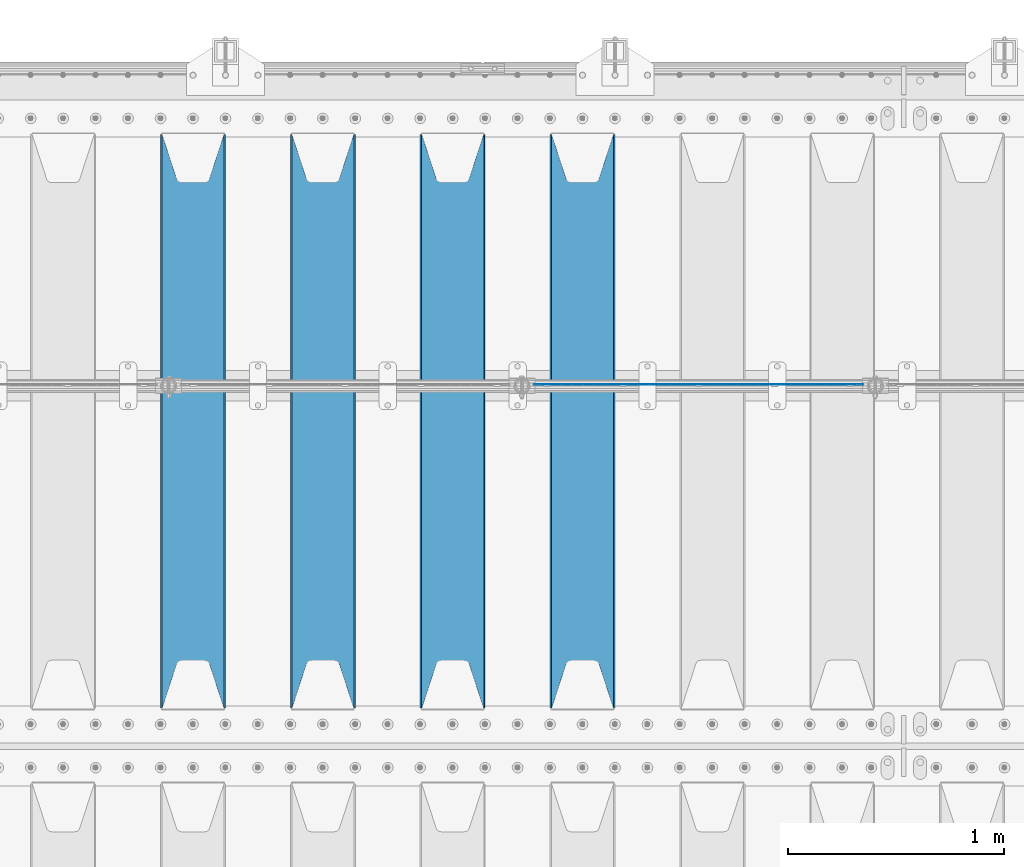
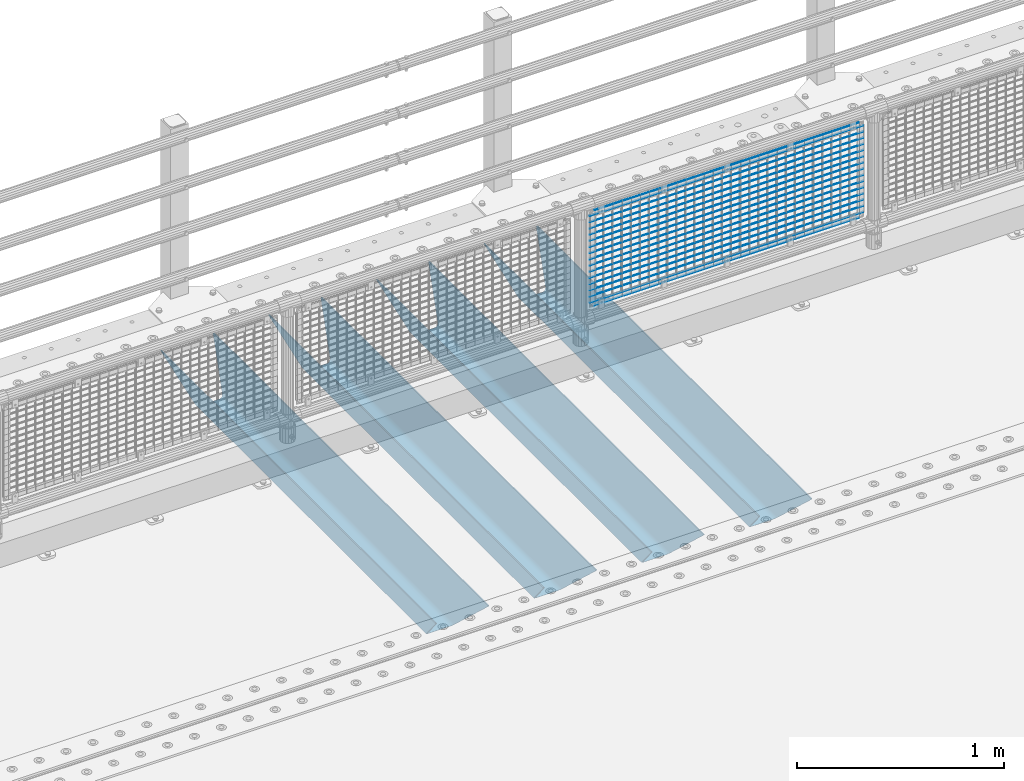
# One storey, part 116 of 242: 21 beams.
"""IFC2X3 building model written with IfcOpenShell, lengths in millimetres."""

from ifc_helpers import new_model, si_unit, frame, origin_with_axes, place, context, subcontext, project, spatial, faceted_brep, material, type_object, element, save


model = new_model("IFC2X3")

# Units and contexts
model_context = context("Model", 3, precision=1e-05, world=origin_with_axes())
body_context = subcontext(model_context, "Body", "Model", "MODEL_VIEW")
ifc_project = project(units=[si_unit("LENGTHUNIT", "METRE", prefix="MILLI"), si_unit("AREAUNIT", "SQUARE_METRE"), si_unit("VOLUMEUNIT", "CUBIC_METRE"), si_unit("MASSUNIT", "GRAM", prefix="KILO"), si_unit("TIMEUNIT", "SECOND"), si_unit("PLANEANGLEUNIT", "RADIAN"), si_unit("SOLIDANGLEUNIT", "STERADIAN"), si_unit("THERMODYNAMICTEMPERATUREUNIT", "DEGREE_CELSIUS"), si_unit("LUMINOUSINTENSITYUNIT", "LUMEN")], contexts=[model_context])

# Site, building, storey
site_placement = place(None, origin_with_axes())
site = spatial("IfcSite", under=ifc_project, at=site_placement, CompositionType="ELEMENT")
building_placement = place(site_placement, origin_with_axes())
building = spatial("IfcBuilding", under=site, at=building_placement, Name="Standard", CompositionType="ELEMENT")
storey_placement = place(building_placement, origin_with_axes())
storey = spatial("IfcBuildingStorey", under=building, at=storey_placement, Name="Undefined", CompositionType="ELEMENT", Elevation=0.0)

# Beams
ifc_material_1 = material(Name="Misc_Undefined")
beam_type_1 = type_object("IfcBeamType", Name="D3", PredefinedType="NOTDEFINED")
for number, where, z_axis, x_axis in (
    (1, (-36875.0, -19329.5, 851.596999999999), (0.0, 0.0, 1.0), (1.0, 0.0, 0.0)),
    (2, (-36875.0, -19329.5, 669.452), (0.0, 0.0, 1.0), (1.0, 0.0, 0.0)),
    (3, (-36875.0, -19329.5, 523.736), (0.0, 0.0, 1.0), (1.0, 0.0, 0.0)),
    (4, (-36875.0, -19329.5, 487.307), (0.0, 0.0, 1.0), (1.0, 0.0, 0.0)),
    (5, (-36875.0, -19329.5, 705.881), (0.0, 0.0, 1.0), (1.0, 0.0, 0.0)),
    (6, (-36875.0, -19329.5, 596.594), (0.0, 0.0, 1.0), (1.0, 0.0, 0.0)),
    (7, (-36875.0, -19329.5, 450.878), (0.0, 0.0, 1.0), (1.0, 0.0, 0.0)),
    (8, (-36875.0, -19329.5, 815.167999999999), (0.0, 0.0, 1.0), (1.0, 0.0, 0.0)),
    (9, (-36875.0, -19329.5, 888.025999999999), (0.0, 0.0, 1.0), (1.0, 0.0, 0.0)),
    (10, (-36875.0, -19329.5, 778.738999999999), (0.0, 0.0, 1.0), (1.0, 0.0, 0.0)),
    (11, (-36875.0, -19329.5, 742.309999999999), (0.0, 0.0, 1.0), (1.0, 0.0, 0.0)),
    (12, (-36875.0, -19329.5, 633.023), (0.0, 0.0, 1.0), (1.0, 0.0, 0.0)),
    (13, (-36875.0, -19329.5, 560.165), (0.0, 0.0, 1.0), (1.0, 0.0, 0.0)),
    (14, (-36875.0, -19329.5, 414.449), (0.0, 0.0, 1.0), (1.0, 0.0, 0.0)),
):
    element("IfcBeam", number, at=place(storey_placement, frame(where, z_axis=z_axis, x_axis=x_axis)), inside=storey, type_object=beam_type_1, material=ifc_material_1, ObjectType="D3", context=body_context, shape_type="Brep", body=[
        faceted_brep([(0.0, -1.50000000000364, 0.0), (-3.63797880709171e-12, -0.750000000003638, -1.29903810567669), (1523.0, -0.75, -1.29903810567669), (1523.0, -1.5, 0.0), (0.0, 0.749999999996362, -1.29903810567669), (1523.0, 0.75, -1.29903810567669), (-3.63797880709171e-12, 1.49999999999636, 0.0), (1523.0, 1.5, 0.0), (0.0, 0.749999999996362, 1.29903810567669), (1523.0, 0.75, 1.29903810567669), (-3.63797880709171e-12, -0.750000000003638, 1.29903810567669), (1523.0, -0.75, 1.29903810567669)], [[[0, 1, 2, 3]], [[1, 4, 5, 2]], [[4, 6, 7, 5]], [[6, 8, 9, 7]], [[8, 10, 11, 9]], [[10, 0, 3, 11]], [[5, 7, 9, 11, 3, 2]], [[10, 8, 6, 4, 1, 0]]]),
    ])
beam_1_placement = place(storey_placement, frame((-36850.0, -19329.5, 353.02), z_axis=(0.0, 0.0, 1.0), x_axis=(1.0, 0.0, 0.0)))
element("IfcBeam", 15, at=beam_1_placement, inside=storey, type_object=beam_type_1, material=ifc_material_1, ObjectType="D3", context=body_context, shape_type="Brep", body=[
    faceted_brep([(0.0, -1.50000000000364, 0.0), (-3.63797880709171e-12, -0.750000000003638, -1.29903810567669), (1473.0, -0.75, -1.29903810567669), (1473.0, -1.5, 0.0), (0.0, 0.749999999996362, -1.29903810567669), (1473.0, 0.75, -1.29903810567663), (-3.63797880709171e-12, 1.49999999999636, 0.0), (1473.0, 1.5, 0.0), (0.0, 0.749999999996362, 1.29903810567669), (1473.0, 0.75, 1.29903810567669), (-3.63797880709171e-12, -0.750000000003638, 1.29903810567669), (1473.0, -0.75, 1.29903810567669)], [[[0, 1, 2, 3]], [[1, 4, 5, 2]], [[4, 6, 7, 5]], [[6, 8, 9, 7]], [[8, 10, 11, 9]], [[10, 0, 3, 11]], [[5, 7, 9, 11, 3, 2]], [[10, 8, 6, 4, 1, 0]]]),
])
beam_2_placement = place(storey_placement, frame((-36875.0, -19329.5, 378.02), z_axis=(0.0, 0.0, 1.0), x_axis=(1.0, 0.0, 0.0)))
element("IfcBeam", 16, at=beam_2_placement, inside=storey, type_object=beam_type_1, material=ifc_material_1, ObjectType="D3", context=body_context, shape_type="Brep", body=[
    faceted_brep([(0.0, -1.50000000000364, 0.0), (-3.63797880709171e-12, -0.750000000003638, -1.29903810567669), (1523.0, -0.75, -1.29903810567669), (1523.0, -1.5, 0.0), (0.0, 0.749999999996362, -1.29903810567669), (1523.0, 0.75, -1.29903810567669), (-3.63797880709171e-12, 1.49999999999636, 0.0), (1523.0, 1.5, 0.0), (0.0, 0.749999999996362, 1.29903810567669), (1523.0, 0.75, 1.29903810567669), (-3.63797880709171e-12, -0.750000000003638, 1.29903810567669), (1523.0, -0.75, 1.29903810567669)], [[[0, 1, 2, 3]], [[1, 4, 5, 2]], [[4, 6, 7, 5]], [[6, 8, 9, 7]], [[8, 10, 11, 9]], [[10, 0, 3, 11]], [[5, 7, 9, 11, 3, 2]], [[10, 8, 6, 4, 1, 0]]]),
])
beam_3_placement = place(storey_placement, frame((-36850.0, -19329.5, 913.02), z_axis=(0.0, 0.0, 1.0), x_axis=(1.0, 0.0, 0.0)))
element("IfcBeam", 17, at=beam_3_placement, inside=storey, type_object=beam_type_1, material=ifc_material_1, ObjectType="D3", context=body_context, shape_type="Brep", body=[
    faceted_brep([(0.0, -1.50000000000364, 0.0), (-3.63797880709171e-12, -0.750000000003638, -1.29903810567669), (1473.0, -0.75, -1.29903810567669), (1473.0, -1.5, 0.0), (0.0, 0.749999999996362, -1.29903810567669), (1473.0, 0.75, -1.29903810567663), (-3.63797880709171e-12, 1.49999999999636, 0.0), (1473.0, 1.5, 0.0), (0.0, 0.749999999996362, 1.29903810567669), (1473.0, 0.75, 1.29903810567669), (-3.63797880709171e-12, -0.750000000003638, 1.29903810567669), (1473.0, -0.75, 1.29903810567669)], [[[0, 1, 2, 3]], [[1, 4, 5, 2]], [[4, 6, 7, 5]], [[6, 8, 9, 7]], [[8, 10, 11, 9]], [[10, 0, 3, 11]], [[5, 7, 9, 11, 3, 2]], [[10, 8, 6, 4, 1, 0]]]),
])
ifc_material_2 = material(Name="STEEL/S355N")
beam_type_2 = type_object("IfcBeamType", PredefinedType="NOTDEFINED")
beam_4_placement = place(storey_placement, frame((-36650.0, -20825.0, -115.0), z_axis=(0.0, 0.0, 1.0), x_axis=(0.0, 1.0, 0.0)))
element("IfcBeam", 18, at=beam_4_placement, inside=storey, type_object=beam_type_2, material=ifc_material_2, context=body_context, shape_type="Brep", body=[
    faceted_brep([(0.0, 150.0, 115.0), (0.0, 143.689999999999, 115.0), (2650.00000000297, 143.689999999999, 115.0), (2650.00000000297, 150.0, 115.0), (2650.00000000297, 142.059565218402, 110.000000003099), (2650.00000000297, 148.369565218403, 110.000000003099), (2441.90079219209, -80.1103600731112, -98.0992078077845), (2437.7588105432, -77.5672621345584, -102.241189456673), (2434.06523489747, -74.4080125315522, -105.934765102404), (2430.91086095089, -70.710272125576, -109.089139048974), (2428.37322971128, -66.5649389910068, -111.626770288588), (2426.51472138055, -62.0739139532889, -113.485278619323), (2425.38102192092, -57.3475956567672, -114.618978078955), (2424.99999999987, -52.5021667386536, -115.0), (2424.99999999987, 52.5021667386536, -115.0), (2425.38102192092, 57.3475956567672, -114.618978078955), (2426.51472138055, 62.0739139532889, -113.485278619323), (2428.37322971128, 66.5649389910068, -111.626770288588), (2430.91086095089, 70.710272125576, -109.089139048974), (2434.06523489747, 74.4080125315522, -105.934765102404), (2437.7588105432, 77.5672621345584, -102.241189456673), (2441.90079219209, 80.1103600731112, -98.0992078077846), (2446.38936140511, 81.9747917625791, -93.6106385947584), (2448.2494850041, 76.2713538057251, -91.7505149957729), (2444.62967112262, 74.76777986261, -95.3703288772456), (2441.28936334126, 72.7168944282894, -98.710636658607), (2438.31067330438, 70.1691124903846, -101.689326695487), (2435.76682334747, 67.1870637758839, -104.233176652398), (2433.72034654133, 63.8440531834895, -106.279653458539), (2432.22154950042, 60.222258798236, -107.778450499454), (2431.30727574265, 56.4107117849089, -108.692724257221), (2430.99999999987, 52.5031078186876, -109.0), (2430.99999999987, -52.5031078186876, -109.0), (2431.30727574265, -56.4107117849089, -108.692724257221), (2432.22154950042, -60.222258798236, -107.778450499454), (2433.72034654133, -63.8440531834895, -106.279653458539), (2435.76682334747, -67.1870637758839, -104.233176652398), (2438.31067330438, -70.1691124903846, -101.689326695487), (2441.28936334126, -72.7168944282894, -98.7106366586071), (2444.62967112262, -74.76777986261, -95.3703288772457), (2448.2494850041, -76.2713538057251, -91.7505149957729), (2650.00000000297, -142.059565218402, 110.000000003099), (2650.00000000297, -148.369565218403, 110.000000003099), (2446.38936140511, -81.9747917625791, -93.6106385947584), (2650.00000000297, -143.689999999999, 115.0), (2650.00000000297, -150.0, 115.0), (0.0, -143.689999999999, 115.0), (0.0, -150.0, 115.0), (0.0, -148.369565218261, 110.000000002669), (203.610638597427, -81.9747917625791, -93.6106385947584), (208.099207810454, -80.1103600731112, -98.0992078077845), (212.241189459342, -77.5672621345584, -102.241189456673), (215.934765105074, -74.4080125315522, -105.934765102404), (219.089139051644, -70.710272125576, -109.089139048974), (221.626770291256, -66.5649389910068, -111.626770288588), (223.485278621993, -62.0739139532889, -113.485278619323), (224.618978081624, -57.3475956567672, -114.618978078955), (225.00000000267, -52.5021667386536, -115.0), (225.00000000267, 52.5021667386536, -115.0), (224.618978081624, 57.3475956567672, -114.618978078955), (223.485278621993, 62.0739139532889, -113.485278619323), (221.626770291256, 66.5649389910068, -111.626770288588), (219.089139051644, 70.710272125576, -109.089139048974), (215.934765105074, 74.4080125315522, -105.934765102404), (212.241189459342, 77.5672621345584, -102.241189456673), (208.099207810454, 80.1103600731112, -98.0992078077846), (203.610638597427, 81.9747917625791, -93.6106385947584), (0.0, 148.369565218261, 110.000000002669), (0.0, 142.05956521826, 110.000000002669), (201.750514998443, 76.2713538057251, -91.7505149957729), (205.370328879915, 74.76777986261, -95.3703288772456), (208.710636661275, 72.7168944282894, -98.710636658607), (211.689326698157, 70.1691124903846, -101.689326695487), (214.233176655067, 67.1870637758839, -104.233176652398), (216.279653461206, 63.8440531834895, -106.279653458539), (217.778450502123, 60.222258798236, -107.778450499454), (218.69272425989, 56.4107117849089, -108.692724257221), (219.00000000267, 52.5031078186876, -109.0), (219.00000000267, -52.5031078186876, -109.0), (218.69272425989, -56.4107117849089, -108.692724257221), (217.778450502123, -60.222258798236, -107.778450499454), (216.279653461206, -63.8440531834895, -106.279653458539), (214.233176655067, -67.1870637758839, -104.233176652398), (211.689326698157, -70.1691124903846, -101.689326695487), (208.710636661275, -72.7168944282894, -98.7106366586071), (205.370328879915, -74.76777986261, -95.3703288772457), (201.750514998443, -76.2713538057251, -91.7505149957729), (0.0, -142.05956521826, 110.000000002669)], [[[0, 1, 2, 3]], [[3, 2, 4, 5]], [[6, 7, 8, 9, 10, 11, 12, 13, 14, 15, 16, 17, 18, 19, 20, 21, 22, 5, 4, 23, 24, 25, 26, 27, 28, 29, 30, 31, 32, 33, 34, 35, 36, 37, 38, 39, 40, 41, 42, 43]], [[44, 45, 42, 41]], [[46, 47, 45, 44]], [[43, 42, 45, 47, 48, 49]], [[6, 43, 49, 50]], [[7, 6, 50, 51]], [[8, 7, 51, 52]], [[9, 8, 52, 53]], [[10, 9, 53, 54]], [[11, 10, 54, 55]], [[12, 11, 55, 56]], [[13, 12, 56, 57]], [[14, 13, 57, 58]], [[15, 14, 58, 59]], [[16, 15, 59, 60]], [[17, 16, 60, 61]], [[18, 17, 61, 62]], [[19, 18, 62, 63]], [[20, 19, 63, 64]], [[21, 20, 64, 65]], [[22, 21, 65, 66]], [[0, 3, 5, 22, 66, 67]], [[1, 0, 67, 68]], [[23, 4, 2, 1, 68, 69]], [[24, 23, 69, 70]], [[25, 24, 70, 71]], [[26, 25, 71, 72]], [[27, 26, 72, 73]], [[28, 27, 73, 74]], [[29, 28, 74, 75]], [[30, 29, 75, 76]], [[31, 30, 76, 77]], [[32, 31, 77, 78]], [[33, 32, 78, 79]], [[34, 33, 79, 80]], [[35, 34, 80, 81]], [[36, 35, 81, 82]], [[37, 36, 82, 83]], [[38, 37, 83, 84]], [[39, 38, 84, 85]], [[40, 39, 85, 86]], [[46, 44, 41, 40, 86, 87]], [[47, 46, 87, 48]], [[86, 85, 84, 83, 82, 81, 80, 79, 78, 77, 76, 75, 74, 73, 72, 71, 70, 69, 68, 67, 66, 65, 64, 63, 62, 61, 60, 59, 58, 57, 56, 55, 54, 53, 52, 51, 50, 49, 48, 87]]]),
])
beam_5_placement = place(storey_placement, frame((-37250.0, -20825.0, -115.0), z_axis=(0.0, 0.0, 1.0), x_axis=(0.0, 1.0, 0.0)))
element("IfcBeam", 19, at=beam_5_placement, inside=storey, type_object=beam_type_2, material=ifc_material_2, context=body_context, shape_type="Brep", body=[
    faceted_brep([(0.0, 150.0, 115.0), (0.0, 143.689999999999, 115.0), (2650.00000000297, 143.689999999999, 115.0), (2650.00000000297, 150.0, 115.0), (2650.00000000297, 142.059565218402, 110.000000003099), (2650.00000000297, 148.369565218403, 110.000000003099), (2441.90079219209, -80.1103600731112, -98.0992078077845), (2437.7588105432, -77.5672621345584, -102.241189456673), (2434.06523489747, -74.4080125315522, -105.934765102404), (2430.91086095089, -70.710272125576, -109.089139048974), (2428.37322971128, -66.5649389910068, -111.626770288588), (2426.51472138055, -62.0739139532889, -113.485278619323), (2425.38102192092, -57.3475956567672, -114.618978078955), (2424.99999999987, -52.5021667386536, -115.0), (2424.99999999987, 52.5021667386536, -115.0), (2425.38102192092, 57.3475956567672, -114.618978078955), (2426.51472138055, 62.0739139532889, -113.485278619323), (2428.37322971128, 66.5649389910068, -111.626770288588), (2430.91086095089, 70.710272125576, -109.089139048974), (2434.06523489747, 74.4080125315522, -105.934765102404), (2437.7588105432, 77.5672621345584, -102.241189456673), (2441.90079219209, 80.1103600731112, -98.0992078077846), (2446.38936140511, 81.9747917625791, -93.6106385947584), (2448.2494850041, 76.2713538057251, -91.7505149957729), (2444.62967112262, 74.76777986261, -95.3703288772456), (2441.28936334126, 72.7168944282894, -98.710636658607), (2438.31067330438, 70.1691124903846, -101.689326695487), (2435.76682334747, 67.1870637758839, -104.233176652398), (2433.72034654133, 63.8440531834895, -106.279653458539), (2432.22154950042, 60.222258798236, -107.778450499454), (2431.30727574265, 56.4107117849089, -108.692724257221), (2430.99999999987, 52.5031078186876, -109.0), (2430.99999999987, -52.5031078186876, -109.0), (2431.30727574265, -56.4107117849089, -108.692724257221), (2432.22154950042, -60.222258798236, -107.778450499454), (2433.72034654133, -63.8440531834895, -106.279653458539), (2435.76682334747, -67.1870637758839, -104.233176652398), (2438.31067330438, -70.1691124903846, -101.689326695487), (2441.28936334126, -72.7168944282894, -98.7106366586071), (2444.62967112262, -74.76777986261, -95.3703288772457), (2448.2494850041, -76.2713538057251, -91.7505149957729), (2650.00000000297, -142.059565218402, 110.000000003099), (2650.00000000297, -148.369565218403, 110.000000003099), (2446.38936140511, -81.9747917625791, -93.6106385947584), (2650.00000000297, -143.689999999999, 115.0), (2650.00000000297, -150.0, 115.0), (0.0, -143.689999999999, 115.0), (0.0, -150.0, 115.0), (0.0, -148.369565218261, 110.000000002669), (203.610638597427, -81.9747917625791, -93.6106385947584), (208.099207810454, -80.1103600731112, -98.0992078077845), (212.241189459342, -77.5672621345584, -102.241189456673), (215.934765105074, -74.4080125315522, -105.934765102404), (219.089139051644, -70.710272125576, -109.089139048974), (221.626770291256, -66.5649389910068, -111.626770288588), (223.485278621993, -62.0739139532889, -113.485278619323), (224.618978081624, -57.3475956567672, -114.618978078955), (225.00000000267, -52.5021667386536, -115.0), (225.00000000267, 52.5021667386536, -115.0), (224.618978081624, 57.3475956567672, -114.618978078955), (223.485278621993, 62.0739139532889, -113.485278619323), (221.626770291256, 66.5649389910068, -111.626770288588), (219.089139051644, 70.710272125576, -109.089139048974), (215.934765105074, 74.4080125315522, -105.934765102404), (212.241189459342, 77.5672621345584, -102.241189456673), (208.099207810454, 80.1103600731112, -98.0992078077846), (203.610638597427, 81.9747917625791, -93.6106385947584), (0.0, 148.369565218261, 110.000000002669), (0.0, 142.05956521826, 110.000000002669), (201.750514998443, 76.2713538057251, -91.7505149957729), (205.370328879915, 74.76777986261, -95.3703288772456), (208.710636661275, 72.7168944282894, -98.710636658607), (211.689326698157, 70.1691124903846, -101.689326695487), (214.233176655067, 67.1870637758839, -104.233176652398), (216.279653461206, 63.8440531834895, -106.279653458539), (217.778450502123, 60.222258798236, -107.778450499454), (218.69272425989, 56.4107117849089, -108.692724257221), (219.00000000267, 52.5031078186876, -109.0), (219.00000000267, -52.5031078186876, -109.0), (218.69272425989, -56.4107117849089, -108.692724257221), (217.778450502123, -60.222258798236, -107.778450499454), (216.279653461206, -63.8440531834895, -106.279653458539), (214.233176655067, -67.1870637758839, -104.233176652398), (211.689326698157, -70.1691124903846, -101.689326695487), (208.710636661275, -72.7168944282894, -98.7106366586071), (205.370328879915, -74.76777986261, -95.3703288772457), (201.750514998443, -76.2713538057251, -91.7505149957729), (0.0, -142.05956521826, 110.000000002669)], [[[0, 1, 2, 3]], [[3, 2, 4, 5]], [[6, 7, 8, 9, 10, 11, 12, 13, 14, 15, 16, 17, 18, 19, 20, 21, 22, 5, 4, 23, 24, 25, 26, 27, 28, 29, 30, 31, 32, 33, 34, 35, 36, 37, 38, 39, 40, 41, 42, 43]], [[44, 45, 42, 41]], [[46, 47, 45, 44]], [[43, 42, 45, 47, 48, 49]], [[6, 43, 49, 50]], [[7, 6, 50, 51]], [[8, 7, 51, 52]], [[9, 8, 52, 53]], [[10, 9, 53, 54]], [[11, 10, 54, 55]], [[12, 11, 55, 56]], [[13, 12, 56, 57]], [[14, 13, 57, 58]], [[15, 14, 58, 59]], [[16, 15, 59, 60]], [[17, 16, 60, 61]], [[18, 17, 61, 62]], [[19, 18, 62, 63]], [[20, 19, 63, 64]], [[21, 20, 64, 65]], [[22, 21, 65, 66]], [[0, 3, 5, 22, 66, 67]], [[1, 0, 67, 68]], [[23, 4, 2, 1, 68, 69]], [[24, 23, 69, 70]], [[25, 24, 70, 71]], [[26, 25, 71, 72]], [[27, 26, 72, 73]], [[28, 27, 73, 74]], [[29, 28, 74, 75]], [[30, 29, 75, 76]], [[31, 30, 76, 77]], [[32, 31, 77, 78]], [[33, 32, 78, 79]], [[34, 33, 79, 80]], [[35, 34, 80, 81]], [[36, 35, 81, 82]], [[37, 36, 82, 83]], [[38, 37, 83, 84]], [[39, 38, 84, 85]], [[40, 39, 85, 86]], [[46, 44, 41, 40, 86, 87]], [[47, 46, 87, 48]], [[86, 85, 84, 83, 82, 81, 80, 79, 78, 77, 76, 75, 74, 73, 72, 71, 70, 69, 68, 67, 66, 65, 64, 63, 62, 61, 60, 59, 58, 57, 56, 55, 54, 53, 52, 51, 50, 49, 48, 87]]]),
])
beam_6_placement = place(storey_placement, frame((-37850.0, -20825.0, -115.0), z_axis=(0.0, 0.0, 1.0), x_axis=(0.0, 1.0, 0.0)))
element("IfcBeam", 20, at=beam_6_placement, inside=storey, type_object=beam_type_2, material=ifc_material_2, context=body_context, shape_type="Brep", body=[
    faceted_brep([(0.0, 150.0, 115.0), (0.0, 143.689999999999, 115.0), (2650.00000000297, 143.689999999999, 115.0), (2650.00000000297, 150.0, 115.0), (2650.00000000297, 142.059565218402, 110.000000003099), (2650.00000000297, 148.369565218403, 110.000000003099), (2441.90079219209, -80.1103600731112, -98.0992078077845), (2437.7588105432, -77.5672621345584, -102.241189456673), (2434.06523489747, -74.4080125315522, -105.934765102404), (2430.91086095089, -70.710272125576, -109.089139048974), (2428.37322971128, -66.5649389910068, -111.626770288588), (2426.51472138055, -62.0739139532889, -113.485278619323), (2425.38102192092, -57.3475956567672, -114.618978078955), (2424.99999999987, -52.5021667386536, -115.0), (2424.99999999987, 52.5021667386536, -115.0), (2425.38102192092, 57.3475956567672, -114.618978078955), (2426.51472138055, 62.0739139532889, -113.485278619323), (2428.37322971128, 66.5649389910068, -111.626770288588), (2430.91086095089, 70.710272125576, -109.089139048974), (2434.06523489747, 74.4080125315522, -105.934765102404), (2437.7588105432, 77.5672621345584, -102.241189456673), (2441.90079219209, 80.1103600731112, -98.0992078077846), (2446.38936140511, 81.9747917625791, -93.6106385947584), (2448.2494850041, 76.2713538057251, -91.7505149957729), (2444.62967112262, 74.76777986261, -95.3703288772456), (2441.28936334126, 72.7168944282894, -98.710636658607), (2438.31067330438, 70.1691124903846, -101.689326695487), (2435.76682334747, 67.1870637758839, -104.233176652398), (2433.72034654133, 63.8440531834895, -106.279653458539), (2432.22154950042, 60.222258798236, -107.778450499454), (2431.30727574265, 56.4107117849089, -108.692724257221), (2430.99999999987, 52.5031078186876, -109.0), (2430.99999999987, -52.5031078186876, -109.0), (2431.30727574265, -56.4107117849089, -108.692724257221), (2432.22154950042, -60.222258798236, -107.778450499454), (2433.72034654133, -63.8440531834895, -106.279653458539), (2435.76682334747, -67.1870637758839, -104.233176652398), (2438.31067330438, -70.1691124903846, -101.689326695487), (2441.28936334126, -72.7168944282894, -98.7106366586071), (2444.62967112262, -74.76777986261, -95.3703288772457), (2448.2494850041, -76.2713538057251, -91.7505149957729), (2650.00000000297, -142.059565218402, 110.000000003099), (2650.00000000297, -148.369565218403, 110.000000003099), (2446.38936140511, -81.9747917625791, -93.6106385947584), (2650.00000000297, -143.689999999999, 115.0), (2650.00000000297, -150.0, 115.0), (0.0, -143.689999999999, 115.0), (0.0, -150.0, 115.0), (0.0, -148.369565218261, 110.000000002669), (203.610638597427, -81.9747917625791, -93.6106385947584), (208.099207810454, -80.1103600731112, -98.0992078077845), (212.241189459342, -77.5672621345584, -102.241189456673), (215.934765105074, -74.4080125315522, -105.934765102404), (219.089139051644, -70.710272125576, -109.089139048974), (221.626770291256, -66.5649389910068, -111.626770288588), (223.485278621993, -62.0739139532889, -113.485278619323), (224.618978081624, -57.3475956567672, -114.618978078955), (225.00000000267, -52.5021667386536, -115.0), (225.00000000267, 52.5021667386536, -115.0), (224.618978081624, 57.3475956567672, -114.618978078955), (223.485278621993, 62.0739139532889, -113.485278619323), (221.626770291256, 66.5649389910068, -111.626770288588), (219.089139051644, 70.710272125576, -109.089139048974), (215.934765105074, 74.4080125315522, -105.934765102404), (212.241189459342, 77.5672621345584, -102.241189456673), (208.099207810454, 80.1103600731112, -98.0992078077846), (203.610638597427, 81.9747917625791, -93.6106385947584), (0.0, 148.369565218261, 110.000000002669), (0.0, 142.05956521826, 110.000000002669), (201.750514998443, 76.2713538057251, -91.7505149957729), (205.370328879915, 74.76777986261, -95.3703288772456), (208.710636661275, 72.7168944282894, -98.710636658607), (211.689326698157, 70.1691124903846, -101.689326695487), (214.233176655067, 67.1870637758839, -104.233176652398), (216.279653461206, 63.8440531834895, -106.279653458539), (217.778450502123, 60.222258798236, -107.778450499454), (218.69272425989, 56.4107117849089, -108.692724257221), (219.00000000267, 52.5031078186876, -109.0), (219.00000000267, -52.5031078186876, -109.0), (218.69272425989, -56.4107117849089, -108.692724257221), (217.778450502123, -60.222258798236, -107.778450499454), (216.279653461206, -63.8440531834895, -106.279653458539), (214.233176655067, -67.1870637758839, -104.233176652398), (211.689326698157, -70.1691124903846, -101.689326695487), (208.710636661275, -72.7168944282894, -98.7106366586071), (205.370328879915, -74.76777986261, -95.3703288772457), (201.750514998443, -76.2713538057251, -91.7505149957729), (0.0, -142.05956521826, 110.000000002669)], [[[0, 1, 2, 3]], [[3, 2, 4, 5]], [[6, 7, 8, 9, 10, 11, 12, 13, 14, 15, 16, 17, 18, 19, 20, 21, 22, 5, 4, 23, 24, 25, 26, 27, 28, 29, 30, 31, 32, 33, 34, 35, 36, 37, 38, 39, 40, 41, 42, 43]], [[44, 45, 42, 41]], [[46, 47, 45, 44]], [[43, 42, 45, 47, 48, 49]], [[6, 43, 49, 50]], [[7, 6, 50, 51]], [[8, 7, 51, 52]], [[9, 8, 52, 53]], [[10, 9, 53, 54]], [[11, 10, 54, 55]], [[12, 11, 55, 56]], [[13, 12, 56, 57]], [[14, 13, 57, 58]], [[15, 14, 58, 59]], [[16, 15, 59, 60]], [[17, 16, 60, 61]], [[18, 17, 61, 62]], [[19, 18, 62, 63]], [[20, 19, 63, 64]], [[21, 20, 64, 65]], [[22, 21, 65, 66]], [[0, 3, 5, 22, 66, 67]], [[1, 0, 67, 68]], [[23, 4, 2, 1, 68, 69]], [[24, 23, 69, 70]], [[25, 24, 70, 71]], [[26, 25, 71, 72]], [[27, 26, 72, 73]], [[28, 27, 73, 74]], [[29, 28, 74, 75]], [[30, 29, 75, 76]], [[31, 30, 76, 77]], [[32, 31, 77, 78]], [[33, 32, 78, 79]], [[34, 33, 79, 80]], [[35, 34, 80, 81]], [[36, 35, 81, 82]], [[37, 36, 82, 83]], [[38, 37, 83, 84]], [[39, 38, 84, 85]], [[40, 39, 85, 86]], [[46, 44, 41, 40, 86, 87]], [[47, 46, 87, 48]], [[86, 85, 84, 83, 82, 81, 80, 79, 78, 77, 76, 75, 74, 73, 72, 71, 70, 69, 68, 67, 66, 65, 64, 63, 62, 61, 60, 59, 58, 57, 56, 55, 54, 53, 52, 51, 50, 49, 48, 87]]]),
])
beam_7_placement = place(storey_placement, frame((-38450.0, -20825.0, -115.0), z_axis=(0.0, 0.0, 1.0), x_axis=(0.0, 1.0, 0.0)))
element("IfcBeam", 21, at=beam_7_placement, inside=storey, type_object=beam_type_2, material=ifc_material_2, context=body_context, shape_type="Brep", body=[
    faceted_brep([(0.0, 150.0, 115.0), (0.0, 143.689999999999, 115.0), (2650.00000000297, 143.689999999999, 115.0), (2650.00000000297, 150.0, 115.0), (2650.00000000297, 142.059565218402, 110.000000003099), (2650.00000000297, 148.369565218403, 110.000000003099), (2441.90079219209, -80.1103600731112, -98.0992078077845), (2437.7588105432, -77.5672621345584, -102.241189456673), (2434.06523489747, -74.4080125315522, -105.934765102404), (2430.91086095089, -70.710272125576, -109.089139048974), (2428.37322971128, -66.5649389910068, -111.626770288588), (2426.51472138055, -62.0739139532889, -113.485278619323), (2425.38102192092, -57.3475956567672, -114.618978078955), (2424.99999999987, -52.5021667386536, -115.0), (2424.99999999987, 52.5021667386536, -115.0), (2425.38102192092, 57.3475956567672, -114.618978078955), (2426.51472138055, 62.0739139532889, -113.485278619323), (2428.37322971128, 66.5649389910068, -111.626770288588), (2430.91086095089, 70.710272125576, -109.089139048974), (2434.06523489747, 74.4080125315522, -105.934765102404), (2437.7588105432, 77.5672621345584, -102.241189456673), (2441.90079219209, 80.1103600731112, -98.0992078077846), (2446.38936140511, 81.9747917625791, -93.6106385947584), (2448.2494850041, 76.2713538057251, -91.7505149957729), (2444.62967112262, 74.76777986261, -95.3703288772456), (2441.28936334126, 72.7168944282894, -98.710636658607), (2438.31067330438, 70.1691124903846, -101.689326695487), (2435.76682334747, 67.1870637758839, -104.233176652398), (2433.72034654133, 63.8440531834895, -106.279653458539), (2432.22154950042, 60.222258798236, -107.778450499454), (2431.30727574265, 56.4107117849089, -108.692724257221), (2430.99999999987, 52.5031078186876, -109.0), (2430.99999999987, -52.5031078186876, -109.0), (2431.30727574265, -56.4107117849089, -108.692724257221), (2432.22154950042, -60.222258798236, -107.778450499454), (2433.72034654133, -63.8440531834895, -106.279653458539), (2435.76682334747, -67.1870637758839, -104.233176652398), (2438.31067330438, -70.1691124903846, -101.689326695487), (2441.28936334126, -72.7168944282894, -98.7106366586071), (2444.62967112262, -74.76777986261, -95.3703288772457), (2448.2494850041, -76.2713538057251, -91.7505149957729), (2650.00000000297, -142.059565218402, 110.000000003099), (2650.00000000297, -148.369565218403, 110.000000003099), (2446.38936140511, -81.9747917625791, -93.6106385947584), (2650.00000000297, -143.689999999999, 115.0), (2650.00000000297, -150.0, 115.0), (0.0, -143.689999999999, 115.0), (0.0, -150.0, 115.0), (0.0, -148.369565218261, 110.000000002669), (203.610638597427, -81.9747917625791, -93.6106385947584), (208.099207810454, -80.1103600731112, -98.0992078077845), (212.241189459342, -77.5672621345584, -102.241189456673), (215.934765105074, -74.4080125315522, -105.934765102404), (219.089139051644, -70.710272125576, -109.089139048974), (221.626770291256, -66.5649389910068, -111.626770288588), (223.485278621993, -62.0739139532889, -113.485278619323), (224.618978081624, -57.3475956567672, -114.618978078955), (225.00000000267, -52.5021667386536, -115.0), (225.00000000267, 52.5021667386536, -115.0), (224.618978081624, 57.3475956567672, -114.618978078955), (223.485278621993, 62.0739139532889, -113.485278619323), (221.626770291256, 66.5649389910068, -111.626770288588), (219.089139051644, 70.710272125576, -109.089139048974), (215.934765105074, 74.4080125315522, -105.934765102404), (212.241189459342, 77.5672621345584, -102.241189456673), (208.099207810454, 80.1103600731112, -98.0992078077846), (203.610638597427, 81.9747917625791, -93.6106385947584), (0.0, 148.369565218261, 110.000000002669), (0.0, 142.05956521826, 110.000000002669), (201.750514998443, 76.2713538057251, -91.7505149957729), (205.370328879915, 74.76777986261, -95.3703288772456), (208.710636661275, 72.7168944282894, -98.710636658607), (211.689326698157, 70.1691124903846, -101.689326695487), (214.233176655067, 67.1870637758839, -104.233176652398), (216.279653461206, 63.8440531834895, -106.279653458539), (217.778450502123, 60.222258798236, -107.778450499454), (218.69272425989, 56.4107117849089, -108.692724257221), (219.00000000267, 52.5031078186876, -109.0), (219.00000000267, -52.5031078186876, -109.0), (218.69272425989, -56.4107117849089, -108.692724257221), (217.778450502123, -60.222258798236, -107.778450499454), (216.279653461206, -63.8440531834895, -106.279653458539), (214.233176655067, -67.1870637758839, -104.233176652398), (211.689326698157, -70.1691124903846, -101.689326695487), (208.710636661275, -72.7168944282894, -98.7106366586071), (205.370328879915, -74.76777986261, -95.3703288772457), (201.750514998443, -76.2713538057251, -91.7505149957729), (0.0, -142.05956521826, 110.000000002669)], [[[0, 1, 2, 3]], [[3, 2, 4, 5]], [[6, 7, 8, 9, 10, 11, 12, 13, 14, 15, 16, 17, 18, 19, 20, 21, 22, 5, 4, 23, 24, 25, 26, 27, 28, 29, 30, 31, 32, 33, 34, 35, 36, 37, 38, 39, 40, 41, 42, 43]], [[44, 45, 42, 41]], [[46, 47, 45, 44]], [[43, 42, 45, 47, 48, 49]], [[6, 43, 49, 50]], [[7, 6, 50, 51]], [[8, 7, 51, 52]], [[9, 8, 52, 53]], [[10, 9, 53, 54]], [[11, 10, 54, 55]], [[12, 11, 55, 56]], [[13, 12, 56, 57]], [[14, 13, 57, 58]], [[15, 14, 58, 59]], [[16, 15, 59, 60]], [[17, 16, 60, 61]], [[18, 17, 61, 62]], [[19, 18, 62, 63]], [[20, 19, 63, 64]], [[21, 20, 64, 65]], [[22, 21, 65, 66]], [[0, 3, 5, 22, 66, 67]], [[1, 0, 67, 68]], [[23, 4, 2, 1, 68, 69]], [[24, 23, 69, 70]], [[25, 24, 70, 71]], [[26, 25, 71, 72]], [[27, 26, 72, 73]], [[28, 27, 73, 74]], [[29, 28, 74, 75]], [[30, 29, 75, 76]], [[31, 30, 76, 77]], [[32, 31, 77, 78]], [[33, 32, 78, 79]], [[34, 33, 79, 80]], [[35, 34, 80, 81]], [[36, 35, 81, 82]], [[37, 36, 82, 83]], [[38, 37, 83, 84]], [[39, 38, 84, 85]], [[40, 39, 85, 86]], [[46, 44, 41, 40, 86, 87]], [[47, 46, 87, 48]], [[86, 85, 84, 83, 82, 81, 80, 79, 78, 77, 76, 75, 74, 73, 72, 71, 70, 69, 68, 67, 66, 65, 64, 63, 62, 61, 60, 59, 58, 57, 56, 55, 54, 53, 52, 51, 50, 49, 48, 87]]]),
])

save(model, "model.ifc")
